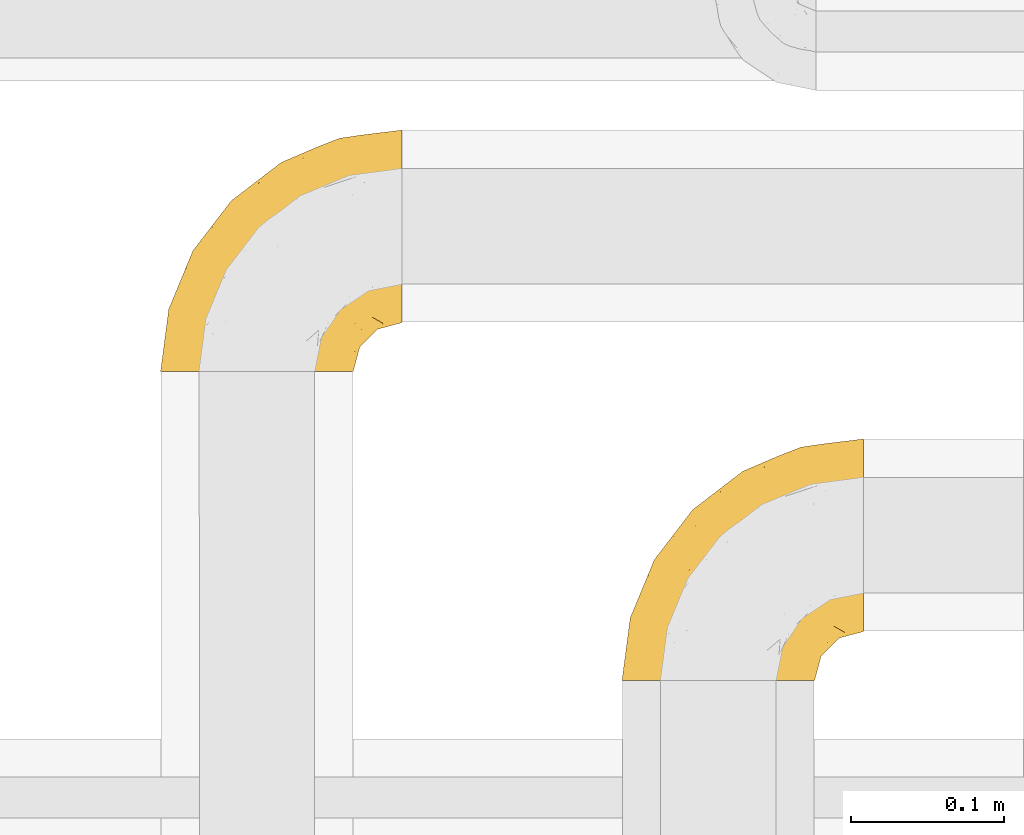
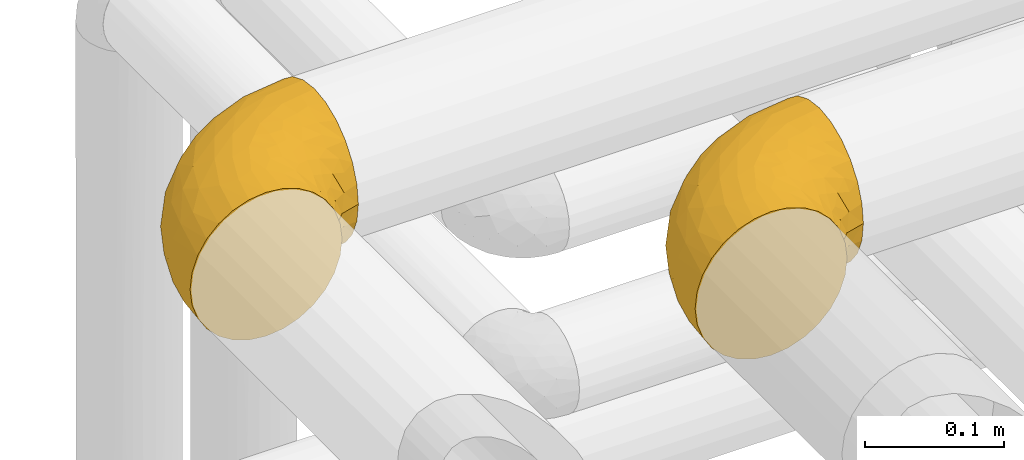
# One storey, part 360 of 827: 2 coverings.
"""IFC2X3 building model written with IfcOpenShell, lengths in millimetres."""

from ifc_helpers import new_model, entity, si_unit, converted_unit, derived_unit, direction, frame, origin, place, context, subcontext, project, spatial, faceted_brep, element, save


model = new_model("IFC2X3")

# Units and contexts
model_context = context("Model", 3, precision=0.01, world=origin(), true_north=direction((6.12303176911189e-17, 1.0)))
body_context = subcontext(model_context, "Body", "Model", "MODEL_VIEW")
ifc_project = project(units=[si_unit("LENGTHUNIT", "METRE", prefix="MILLI"), si_unit("AREAUNIT", "SQUARE_METRE"), si_unit("VOLUMEUNIT", "CUBIC_METRE"), converted_unit("PLANEANGLEUNIT", "DEGREE", entity("IfcRatioMeasure", 0.0174532925199433), si_unit("PLANEANGLEUNIT", "RADIAN"), dimensions=[0, 0, 0, 0, 0, 0, 0]), si_unit("MASSUNIT", "GRAM", prefix="KILO"), derived_unit("MASSDENSITYUNIT", [(si_unit("MASSUNIT", "GRAM", prefix="KILO"), 1), (si_unit("LENGTHUNIT", "METRE"), -3)]), derived_unit("MOMENTOFINERTIAUNIT", [(si_unit("LENGTHUNIT", "METRE"), 4)]), si_unit("TIMEUNIT", "SECOND"), si_unit("FREQUENCYUNIT", "HERTZ"), si_unit("THERMODYNAMICTEMPERATUREUNIT", "DEGREE_CELSIUS"), derived_unit("THERMALTRANSMITTANCEUNIT", [(si_unit("MASSUNIT", "GRAM", prefix="KILO"), 1), (si_unit("THERMODYNAMICTEMPERATUREUNIT", "KELVIN"), -1), (si_unit("TIMEUNIT", "SECOND"), -3)]), derived_unit("VOLUMETRICFLOWRATEUNIT", [(si_unit("LENGTHUNIT", "METRE"), 3), (si_unit("TIMEUNIT", "SECOND"), -1)]), derived_unit("MASSFLOWRATEUNIT", [(si_unit("MASSUNIT", "GRAM", prefix="KILO"), 1), (si_unit("TIMEUNIT", "SECOND"), -1)]), derived_unit("ROTATIONALFREQUENCYUNIT", [(si_unit("TIMEUNIT", "SECOND"), -1)]), si_unit("ELECTRICCURRENTUNIT", "AMPERE"), si_unit("ELECTRICVOLTAGEUNIT", "VOLT"), si_unit("POWERUNIT", "WATT"), si_unit("FORCEUNIT", "NEWTON", prefix="KILO"), si_unit("ILLUMINANCEUNIT", "LUX"), si_unit("LUMINOUSFLUXUNIT", "LUMEN"), si_unit("LUMINOUSINTENSITYUNIT", "CANDELA"), derived_unit("USERDEFINED", [(si_unit("MASSUNIT", "GRAM", prefix="KILO"), -1), (si_unit("LENGTHUNIT", "METRE"), -2), (si_unit("TIMEUNIT", "SECOND"), 3), (si_unit("LUMINOUSFLUXUNIT", "LUMEN"), 1)]), derived_unit("LINEARVELOCITYUNIT", [(si_unit("LENGTHUNIT", "METRE"), 1), (si_unit("TIMEUNIT", "SECOND"), -1)]), si_unit("PRESSUREUNIT", "PASCAL"), derived_unit("USERDEFINED", [(si_unit("LENGTHUNIT", "METRE"), -2), (si_unit("MASSUNIT", "GRAM", prefix="KILO"), 1), (si_unit("TIMEUNIT", "SECOND"), -2)]), derived_unit("LINEARFORCEUNIT", [(si_unit("MASSUNIT", "GRAM", prefix="KILO"), 1), (si_unit("LENGTHUNIT", "METRE"), 1), (si_unit("TIMEUNIT", "SECOND"), -2), (si_unit("LENGTHUNIT", "METRE"), -1)]), derived_unit("PLANARFORCEUNIT", [(si_unit("MASSUNIT", "GRAM", prefix="KILO"), 1), (si_unit("LENGTHUNIT", "METRE"), 1), (si_unit("TIMEUNIT", "SECOND"), -2), (si_unit("LENGTHUNIT", "METRE"), -2)])], contexts=[model_context])

# Site, building, storey
site_placement = place(None, origin())
site = spatial("IfcSite", under=ifc_project, at=site_placement, CompositionType="ELEMENT")
building_placement = place(site_placement, origin())
building = spatial("IfcBuilding", under=site, at=building_placement, CompositionType="ELEMENT")
storey_placement = place(building_placement, frame((0.0, 0.0, 28200.0)))
storey = spatial("IfcBuildingStorey", under=building, at=storey_placement, Name="08", CompositionType="ELEMENT", Elevation=28200.0)

# Coverings
covering_1_placement = place(storey_placement, frame((35853.29, 18712.29, 3485.35)))
element("IfcCovering", 1, at=covering_1_placement, inside=storey, Name=":ADSK_", ObjectType=":ADSK_", PredefinedType="INSULATION", context=body_context, shape_type="Brep", body=[
    faceted_brep([(50.62, 1.61, 126.11), (37.29, 1.6, 121.45), (25.34, 1.6, 113.94), (15.35, 1.6, 103.96), (7.84, 1.6, 92.0), (3.18, 1.6, 78.68), (1.6, 1.6, 64.65), (3.18, 1.6, 50.62), (7.84, 1.6, 37.29), (15.35, 1.6, 25.34), (25.33, 1.6, 15.35), (37.29, 1.6, 7.84), (50.61, 1.61, 3.18), (64.65, 1.61, 1.6), (78.67, 1.61, 3.18), (92.0, 1.62, 7.84), (103.95, 1.62, 15.35), (113.94, 1.62, 25.33), (121.45, 1.62, 37.29), (126.11, 1.62, 50.61), (127.7, 1.62, 64.65), (126.11, 1.62, 78.67), (121.45, 1.62, 92.0), (113.94, 1.62, 103.95), (103.96, 1.62, 113.94), (92.0, 1.62, 121.45), (78.68, 1.61, 126.11), (64.65, 1.61, 127.7), (159.65, 33.58, 64.65), (159.65, 35.73, 48.33), (159.65, 42.03, 33.12), (159.65, 52.05, 20.06), (159.65, 65.11, 10.04), (159.65, 80.31, 3.74), (159.65, 85.92, 3.01), (159.65, 96.63, 1.6), (159.65, 112.95, 3.74), (159.65, 128.16, 10.04), (159.65, 141.22, 20.06), (159.65, 151.24, 33.12), (159.65, 157.53, 48.33), (159.65, 159.68, 64.65), (159.65, 157.53, 80.96), (159.65, 151.24, 96.17), (159.65, 141.22, 109.23), (159.65, 128.16, 119.25), (159.65, 112.95, 125.55), (159.65, 96.63, 127.7), (159.65, 85.92, 126.29), (159.65, 80.31, 125.55), (159.65, 65.11, 119.25), (159.65, 52.05, 109.23), (159.65, 42.03, 96.17), (159.65, 35.73, 80.96), (131.11, 145.27, 101.1), (121.84, 150.98, 86.72), (98.59, 136.52, 98.7), (132.73, 156.34, 75.93), (118.73, 154.3, 64.65), (45.66, 73.94, 113.39), (62.28, 98.97, 111.06), (49.94, 102.75, 96.87), (65.73, 124.92, 84.07), (80.61, 138.5, 64.65), (47.87, 113.38, 64.65), (117.52, 120.37, 119.55), (90.47, 118.45, 112.74), (98.52, 104.03, 122.85), (128.07, 110.09, 125.08), (107.82, 94.64, 126.64), (30.57, 62.69, 105.78), (23.54, 66.8, 93.81), (14.4, 37.71, 96.07), (94.66, 141.15, 87.11), (103.54, 148.33, 75.77), (121.36, 132.8, 111.99), (6.97, 42.51, 64.65), (9.16, 39.36, 83.58), (35.69, 96.18, 80.97), (18.42, 69.17, 78.34), (57.24, 62.73, 122.85), (81.83, 79.43, 125.88), (72.41, 88.84, 120.96), (56.37, 26.95, 126.67), (43.85, 32.14, 122.64), (103.8, 78.48, 127.7), (117.04, 85.23, 127.7), (130.28, 91.98, 127.7), (21.27, 31.66, 107.12), (34.2, 45.39, 115.07), (74.06, 118.92, 102.8), (82.78, 57.46, 127.7), (88.04, 62.72, 127.7), (93.29, 67.97, 127.7), (66.61, 14.01, 127.7), (67.95, 22.49, 127.7), (69.29, 30.97, 127.7), (66.63, 53.44, 126.64), (76.04, 44.22, 127.7), (22.76, 80.64, 64.65), (147.25, 94.67, 127.7), (120.77, 39.98, 113.06), (128.88, 33.19, 101.82), (132.53, 43.24, 108.46), (145.71, 81.81, 126.21), (132.18, 66.34, 122.65), (121.21, 75.26, 126.55), (115.88, 66.59, 125.45), (134.77, 78.22, 126.01), (113.66, 56.89, 123.31), (124.95, 54.27, 119.0), (105.66, 12.97, 113.51), (116.21, 17.45, 104.6), (103.69, 27.08, 118.04), (149.68, 44.4, 101.6), (142.04, 49.7, 109.99), (151.16, 38.92, 92.1), (140.2, 37.12, 96.28), (145.71, 67.0, 121.06), (147.4, 33.03, 79.4), (128.57, 14.55, 79.19), (136.38, 26.35, 80.4), (126.92, 22.4, 93.14), (79.77, 27.98, 126.75), (89.97, 39.49, 125.71), (79.6, 15.43, 126.17), (131.97, 17.6, 64.65), (90.59, 21.34, 123.28), (129.31, 7.64, 64.65), (133.25, 28.96, 91.58), (119.52, 28.68, 107.1), (111.09, 34.85, 116.29), (143.67, 58.31, 116.32), (123.62, 11.76, 90.34), (100.76, 40.39, 122.74), (143.67, 29.3, 64.65), (104.27, 65.16, 126.78), (112.26, 45.43, 119.84), (103.94, 53.07, 124.71), (92.98, 50.42, 126.47), (151.16, 38.92, 37.19), (144.66, 42.93, 27.66), (147.4, 33.03, 49.89), (147.25, 94.67, 1.6), (128.57, 14.55, 50.09), (136.38, 26.35, 48.89), (93.42, 50.53, 2.88), (100.14, 39.44, 6.55), (89.97, 39.49, 3.58), (103.8, 78.48, 1.6), (117.04, 85.23, 1.6), (121.21, 75.26, 2.74), (103.68, 27.08, 11.25), (110.22, 36.38, 11.93), (118.45, 28.93, 21.08), (134.77, 78.22, 3.28), (132.18, 66.34, 6.64), (143.67, 58.31, 12.97), (142.04, 49.7, 19.3), (120.77, 39.99, 16.23), (132.4, 42.46, 21.44), (127.75, 32.6, 26.96), (145.71, 67.0, 8.24), (145.71, 81.81, 3.08), (124.95, 54.27, 10.29), (123.62, 11.76, 38.95), (140.2, 37.12, 33.01), (66.61, 14.01, 1.6), (67.95, 22.49, 1.6), (126.92, 22.4, 36.15), (116.21, 17.45, 24.69), (90.58, 21.34, 6.01), (79.77, 27.98, 2.54), (105.66, 12.97, 15.78), (69.29, 30.97, 1.6), (79.6, 15.43, 3.12), (133.38, 29.33, 37.33), (82.78, 57.46, 1.6), (76.04, 44.22, 1.6), (104.27, 65.16, 2.51), (115.88, 66.59, 3.84), (113.66, 56.89, 5.99), (112.96, 46.44, 9.35), (93.29, 67.97, 1.6), (103.93, 53.07, 4.58), (130.28, 91.98, 1.6), (98.59, 136.52, 30.59), (131.11, 145.27, 28.19), (121.36, 132.8, 17.3), (117.52, 120.37, 9.74), (121.84, 150.98, 42.57), (105.45, 149.05, 53.51), (132.84, 156.37, 53.42), (107.82, 94.64, 2.65), (56.37, 26.95, 2.62), (43.85, 32.15, 6.66), (57.24, 62.73, 6.45), (35.69, 96.18, 48.32), (49.94, 102.75, 32.42), (23.54, 66.8, 35.49), (66.63, 53.44, 2.65), (81.83, 79.43, 3.41), (128.07, 110.09, 4.21), (92.45, 140.47, 43.07), (30.57, 62.69, 23.52), (21.27, 31.66, 22.18), (12.64, 29.32, 33.1), (45.65, 73.94, 15.9), (34.2, 45.39, 14.23), (90.47, 118.45, 16.55), (65.73, 124.92, 45.22), (98.52, 104.03, 6.45), (72.41, 88.84, 8.33), (62.28, 98.97, 18.23), (72.15, 122.88, 32.98), (82.53, 138.42, 53.35), (19.01, 69.19, 48.76), (9.16, 39.36, 45.72)], [[[0, 1, 2, 3, 4, 5, 6, 7, 8, 9, 10, 11, 12, 13, 14, 15, 16, 17, 18, 19, 20, 21, 22, 23, 24, 25, 26, 27]], [[28, 29, 30, 31, 32, 33, 34, 35, 36, 37, 38, 39, 40, 41, 42, 43, 44, 45, 46, 47, 48, 49, 50, 51, 52, 53]], [[54, 55, 56]], [[57, 41, 58]], [[59, 60, 61]], [[62, 63, 64]], [[65, 66, 67]], [[68, 67, 69]], [[70, 71, 72]], [[55, 73, 56]], [[43, 42, 55]], [[55, 74, 73]], [[44, 75, 45]], [[44, 43, 54]], [[76, 5, 77]], [[71, 78, 79]], [[45, 75, 65]], [[46, 68, 47]], [[80, 81, 82]], [[0, 83, 84]], [[69, 85, 86, 87]], [[69, 81, 85]], [[84, 1, 0]], [[2, 88, 3]], [[4, 3, 72]], [[44, 54, 75]], [[5, 4, 77]], [[89, 2, 1]], [[72, 3, 88]], [[5, 76, 6]], [[70, 88, 89]], [[68, 65, 67]], [[88, 2, 89]], [[56, 90, 66]], [[64, 78, 62]], [[81, 91, 92, 93, 85]], [[83, 27, 94, 95, 96]], [[62, 61, 90]], [[97, 96, 98, 91]], [[80, 97, 81]], [[42, 57, 55]], [[62, 78, 61]], [[84, 89, 1]], [[78, 64, 99]], [[57, 74, 55]], [[76, 77, 79]], [[77, 72, 71]], [[82, 81, 67]], [[97, 83, 96]], [[80, 89, 84]], [[79, 78, 99]], [[71, 70, 61]], [[81, 97, 91]], [[83, 80, 84]], [[68, 87, 100, 47]], [[81, 69, 67]], [[68, 69, 87]], [[65, 46, 45]], [[65, 68, 46]], [[66, 65, 75]], [[56, 66, 75]], [[66, 60, 82]], [[71, 61, 78]], [[60, 66, 90]], [[83, 97, 80]], [[27, 83, 0]], [[59, 70, 89]], [[70, 59, 61]], [[89, 80, 59]], [[82, 59, 80]], [[55, 54, 43]], [[75, 54, 56]], [[66, 82, 67]], [[59, 82, 60]], [[41, 57, 42]], [[74, 57, 58]], [[58, 63, 74]], [[62, 74, 63]], [[74, 62, 73]], [[62, 56, 73]], [[4, 72, 77]], [[70, 72, 88]], [[76, 79, 99]], [[71, 79, 77]], [[62, 90, 56]], [[60, 90, 61]], [[101, 102, 103]], [[100, 87, 104]], [[105, 106, 107]], [[108, 104, 87]], [[107, 109, 110]], [[108, 87, 86]], [[111, 112, 113]], [[114, 51, 115]], [[116, 114, 117]], [[51, 50, 118]], [[119, 28, 53]], [[120, 121, 122]], [[98, 123, 124]], [[125, 96, 95]], [[116, 53, 52]], [[126, 121, 120]], [[104, 108, 118]], [[98, 124, 91]], [[25, 24, 127]], [[120, 128, 126]], [[122, 129, 102]], [[95, 94, 27, 26]], [[122, 102, 130]], [[125, 127, 123]], [[24, 111, 127]], [[21, 20, 128]], [[112, 130, 131]], [[48, 47, 100, 49]], [[132, 110, 115]], [[23, 111, 24]], [[129, 119, 117]], [[120, 133, 21]], [[112, 23, 22]], [[134, 113, 131]], [[121, 126, 135]], [[133, 112, 22]], [[128, 120, 21]], [[132, 51, 118]], [[120, 122, 133]], [[119, 121, 135]], [[129, 117, 102]], [[125, 26, 25]], [[26, 125, 95]], [[127, 125, 25]], [[28, 119, 135]], [[119, 53, 116]], [[127, 113, 124]], [[96, 125, 123]], [[112, 131, 113]], [[101, 103, 110]], [[85, 93, 136]], [[124, 123, 127]], [[98, 96, 123]], [[112, 111, 23]], [[127, 111, 113]], [[112, 133, 122]], [[21, 133, 22]], [[107, 110, 105]], [[110, 109, 137]], [[86, 106, 108]], [[138, 109, 136]], [[105, 118, 108]], [[107, 106, 85]], [[104, 50, 49]], [[124, 134, 139]], [[138, 93, 92]], [[92, 91, 139]], [[100, 104, 49]], [[118, 105, 132]], [[104, 118, 50]], [[110, 132, 105]], [[51, 132, 115]], [[108, 106, 105]], [[85, 106, 86]], [[114, 116, 52]], [[119, 116, 117]], [[51, 114, 52]], [[114, 115, 103]], [[117, 114, 103]], [[130, 102, 101]], [[117, 103, 102]], [[110, 103, 115]], [[130, 101, 131]], [[122, 130, 112]], [[101, 137, 131]], [[113, 134, 124]], [[137, 134, 131]], [[124, 139, 91]], [[134, 138, 139]], [[92, 139, 138]], [[110, 137, 101]], [[134, 137, 138]], [[136, 109, 107]], [[137, 109, 138]], [[85, 136, 107]], [[138, 136, 93]], [[122, 121, 129]], [[129, 121, 119]], [[30, 140, 141]], [[30, 29, 140]], [[28, 135, 142]], [[143, 35, 34, 33]], [[19, 144, 128]], [[126, 145, 135]], [[146, 147, 148]], [[149, 150, 151]], [[152, 153, 154]], [[155, 156, 151]], [[157, 31, 158]], [[159, 160, 161]], [[32, 162, 163]], [[158, 31, 30]], [[157, 164, 156]], [[126, 144, 145]], [[126, 128, 144]], [[18, 165, 19]], [[141, 166, 160]], [[14, 13, 167, 168]], [[163, 143, 33]], [[169, 165, 170]], [[18, 17, 170]], [[153, 159, 154]], [[142, 135, 145]], [[148, 171, 172]], [[159, 161, 154]], [[171, 152, 173]], [[173, 17, 16]], [[16, 15, 171]], [[158, 160, 164]], [[174, 175, 168]], [[173, 170, 17]], [[19, 128, 20]], [[174, 172, 175]], [[165, 169, 144]], [[162, 157, 156]], [[175, 172, 171]], [[144, 169, 145]], [[176, 169, 161]], [[166, 140, 142]], [[175, 171, 15]], [[168, 175, 14]], [[14, 175, 15]], [[142, 145, 176]], [[28, 142, 29]], [[148, 177, 146]], [[148, 178, 177]], [[152, 171, 148]], [[179, 180, 181]], [[164, 180, 156]], [[174, 178, 172]], [[148, 172, 178]], [[171, 173, 16]], [[170, 173, 152]], [[19, 165, 144]], [[170, 165, 18]], [[153, 182, 159]], [[146, 183, 184]], [[181, 180, 164]], [[180, 151, 156]], [[163, 155, 185]], [[155, 150, 185]], [[162, 156, 155]], [[143, 163, 185]], [[180, 179, 149]], [[32, 163, 33]], [[163, 162, 155]], [[31, 162, 32]], [[31, 157, 162]], [[164, 157, 158]], [[149, 151, 180]], [[155, 151, 150]], [[142, 140, 29]], [[141, 140, 166]], [[176, 145, 169]], [[30, 141, 158]], [[164, 160, 159]], [[158, 141, 160]], [[166, 161, 160]], [[154, 169, 170]], [[169, 154, 161]], [[152, 154, 170]], [[147, 152, 148]], [[153, 147, 182]], [[181, 182, 184]], [[164, 159, 182]], [[161, 166, 176]], [[142, 176, 166]], [[183, 146, 177]], [[184, 182, 147]], [[184, 147, 146]], [[152, 147, 153]], [[182, 181, 164]], [[179, 184, 183]], [[184, 179, 181]], [[149, 179, 183]], [[186, 187, 188]], [[37, 36, 189]], [[190, 191, 192]], [[193, 185, 150, 149]], [[194, 195, 196]], [[197, 198, 199]], [[200, 201, 177]], [[193, 202, 185]], [[203, 190, 186]], [[202, 189, 36]], [[41, 40, 192]], [[204, 205, 199]], [[9, 8, 206]], [[187, 190, 39]], [[40, 39, 190]], [[38, 37, 188]], [[207, 208, 204]], [[202, 35, 143, 185]], [[39, 38, 187]], [[195, 11, 208]], [[201, 149, 183, 177]], [[188, 189, 209]], [[197, 64, 210]], [[186, 188, 209]], [[13, 12, 194]], [[211, 201, 212]], [[12, 11, 195]], [[193, 201, 211]], [[212, 201, 196]], [[10, 208, 11]], [[213, 214, 209]], [[64, 63, 215]], [[216, 197, 199]], [[8, 217, 206]], [[7, 217, 8]], [[203, 191, 190]], [[7, 6, 76]], [[208, 205, 204]], [[205, 10, 9]], [[199, 205, 206]], [[7, 76, 217]], [[205, 208, 10]], [[216, 76, 99]], [[200, 177, 178, 174]], [[64, 197, 99]], [[63, 58, 191]], [[208, 196, 195]], [[196, 200, 194]], [[198, 197, 210]], [[216, 199, 217]], [[201, 193, 149]], [[202, 193, 211]], [[202, 211, 189]], [[35, 202, 36]], [[211, 212, 209]], [[37, 189, 188]], [[211, 209, 189]], [[213, 198, 214]], [[200, 174, 194]], [[201, 200, 196]], [[214, 198, 210]], [[213, 207, 198]], [[194, 174, 168, 167, 13]], [[195, 194, 12]], [[198, 204, 199]], [[204, 198, 207]], [[212, 207, 213]], [[196, 208, 207]], [[188, 187, 38]], [[190, 187, 186]], [[207, 212, 196]], [[209, 212, 213]], [[214, 203, 186]], [[191, 215, 63]], [[191, 203, 215]], [[192, 191, 58]], [[41, 192, 58]], [[190, 192, 40]], [[203, 210, 215]], [[64, 215, 210]], [[199, 206, 217]], [[9, 206, 205]], [[76, 216, 217]], [[99, 197, 216]], [[203, 214, 210]], [[209, 214, 186]]]),
])
covering_2_placement = place(storey_placement, frame((36155.39, 18510.1, 3485.35)))
element("IfcCovering", 2, at=covering_2_placement, inside=storey, Name=":ADSK_", ObjectType=":ADSK_", PredefinedType="INSULATION", context=body_context, shape_type="Brep", body=[
    faceted_brep([(50.62, 1.6, 126.11), (37.29, 1.6, 121.45), (25.34, 1.6, 113.94), (15.35, 1.6, 103.96), (7.84, 1.6, 92.0), (3.18, 1.6, 78.68), (1.6, 1.6, 64.65), (3.18, 1.6, 50.62), (7.84, 1.6, 37.29), (15.35, 1.6, 25.34), (25.33, 1.6, 15.35), (37.29, 1.6, 7.84), (50.61, 1.6, 3.18), (64.65, 1.6, 1.6), (78.67, 1.6, 3.18), (92.0, 1.6, 7.84), (103.95, 1.6, 15.35), (113.94, 1.6, 25.33), (121.45, 1.6, 37.29), (126.11, 1.6, 50.61), (127.7, 1.6, 64.65), (126.11, 1.6, 78.67), (121.45, 1.6, 92.0), (113.94, 1.6, 103.95), (103.96, 1.6, 113.94), (92.0, 1.6, 121.45), (78.68, 1.6, 126.11), (64.65, 1.6, 127.7), (159.65, 33.55, 64.65), (159.65, 35.69, 48.33), (159.65, 41.99, 33.12), (159.65, 52.01, 20.06), (159.65, 65.07, 10.04), (159.65, 80.28, 3.74), (159.65, 85.89, 3.01), (159.65, 96.6, 1.6), (159.65, 112.91, 3.74), (159.65, 128.12, 10.04), (159.65, 141.18, 20.06), (159.65, 151.2, 33.12), (159.65, 157.5, 48.33), (159.65, 159.65, 64.65), (159.65, 157.5, 80.96), (159.65, 151.2, 96.17), (159.65, 141.18, 109.23), (159.65, 128.12, 119.25), (159.65, 112.91, 125.55), (159.65, 96.6, 127.7), (159.65, 85.89, 126.29), (159.65, 80.28, 125.55), (159.65, 65.07, 119.25), (159.65, 52.01, 109.23), (159.65, 41.99, 96.17), (159.65, 35.69, 80.96), (131.11, 145.23, 101.1), (121.84, 150.95, 86.72), (98.59, 136.48, 98.7), (132.73, 156.3, 75.93), (118.74, 154.26, 64.65), (45.67, 73.92, 113.39), (62.3, 98.94, 111.06), (49.95, 102.72, 96.87), (65.74, 124.89, 84.07), (80.62, 138.47, 64.65), (47.89, 113.35, 64.65), (117.53, 120.33, 119.56), (90.48, 118.42, 112.75), (98.53, 103.99, 122.85), (128.08, 110.05, 125.08), (107.83, 94.6, 126.64), (30.59, 62.68, 105.78), (23.56, 66.8, 93.81), (14.41, 37.71, 96.07), (94.66, 141.12, 87.11), (103.54, 148.29, 75.77), (121.36, 132.76, 111.99), (6.98, 42.5, 64.65), (9.17, 39.36, 83.58), (35.7, 96.16, 80.96), (18.43, 69.16, 78.34), (57.25, 62.71, 122.85), (81.84, 79.4, 125.88), (72.43, 88.81, 120.97), (56.38, 26.93, 126.67), (43.86, 32.13, 122.64), (103.81, 78.45, 127.7), (117.05, 85.2, 127.7), (130.29, 91.95, 127.7), (21.28, 31.66, 107.12), (34.21, 45.38, 115.07), (74.07, 118.88, 102.81), (82.79, 57.43, 127.7), (88.04, 62.69, 127.7), (93.3, 67.94, 127.7), (66.61, 13.99, 127.7), (67.95, 22.47, 127.7), (69.29, 30.95, 127.7), (66.64, 53.41, 126.64), (76.04, 44.19, 127.7), (22.77, 80.62, 64.65), (147.25, 94.63, 127.7), (120.78, 39.95, 113.05), (128.88, 33.15, 101.81), (132.53, 43.2, 108.46), (145.71, 81.77, 126.21), (132.18, 66.3, 122.65), (121.21, 75.23, 126.55), (115.88, 66.55, 125.45), (134.78, 78.18, 126.01), (113.68, 56.85, 123.3), (124.96, 54.23, 118.99), (105.67, 12.94, 113.51), (116.22, 17.42, 104.6), (103.69, 27.05, 118.04), (149.68, 44.37, 101.6), (142.04, 49.66, 109.98), (151.17, 38.88, 92.1), (140.2, 37.08, 96.28), (145.72, 66.96, 121.05), (147.4, 32.99, 79.4), (128.57, 14.52, 79.19), (136.38, 26.32, 80.39), (126.93, 22.37, 93.14), (79.77, 27.96, 126.75), (89.98, 39.47, 125.71), (79.6, 15.41, 126.17), (131.98, 17.57, 64.65), (90.59, 21.32, 123.28), (129.31, 7.61, 64.65), (133.25, 28.92, 91.58), (119.53, 28.65, 107.1), (111.1, 34.82, 116.28), (143.67, 58.27, 116.32), (123.62, 11.73, 90.34), (100.76, 40.36, 122.74), (143.67, 29.26, 64.65), (104.28, 65.12, 126.77), (112.26, 45.4, 119.84), (103.95, 53.05, 124.71), (92.99, 50.39, 126.47), (151.17, 38.88, 37.19), (144.66, 42.9, 27.66), (147.4, 32.99, 49.9), (147.25, 94.63, 1.6), (128.57, 14.52, 50.1), (136.38, 26.32, 48.89), (93.43, 50.51, 2.88), (100.15, 39.41, 6.55), (89.98, 39.47, 3.58), (103.81, 78.45, 1.6), (117.05, 85.2, 1.6), (121.21, 75.23, 2.74), (103.69, 27.05, 11.25), (110.23, 36.34, 11.93), (118.45, 28.89, 21.09), (134.78, 78.18, 3.28), (132.18, 66.3, 6.64), (143.67, 58.27, 12.97), (142.04, 49.66, 19.31), (120.78, 39.95, 16.23), (132.4, 42.42, 21.44), (127.76, 32.56, 26.96), (145.72, 66.96, 8.24), (145.71, 81.77, 3.08), (124.96, 54.23, 10.3), (123.62, 11.73, 38.95), (140.2, 37.08, 33.01), (66.61, 13.99, 1.6), (67.95, 22.47, 1.6), (126.93, 22.37, 36.15), (116.21, 17.42, 24.69), (90.59, 21.32, 6.01), (79.77, 27.96, 2.54), (105.66, 12.94, 15.78), (69.29, 30.95, 1.6), (79.6, 15.41, 3.12), (133.38, 29.3, 37.33), (82.79, 57.43, 1.6), (76.04, 44.19, 1.6), (104.28, 65.12, 2.52), (115.88, 66.55, 3.84), (113.68, 56.85, 5.99), (112.97, 46.41, 9.35), (93.3, 67.94, 1.6), (103.94, 53.04, 4.58), (130.29, 91.95, 1.6), (98.59, 136.48, 30.59), (131.11, 145.23, 28.19), (121.36, 132.76, 17.3), (117.53, 120.33, 9.73), (121.84, 150.95, 42.57), (105.45, 149.01, 53.51), (132.83, 156.33, 53.42), (107.83, 94.6, 2.65), (56.38, 26.93, 2.62), (43.85, 32.14, 6.66), (57.25, 62.71, 6.44), (35.7, 96.16, 48.33), (49.95, 102.72, 32.42), (23.55, 66.79, 35.49), (66.64, 53.41, 2.65), (81.84, 79.4, 3.41), (128.08, 110.05, 4.21), (92.46, 140.44, 43.07), (30.58, 62.68, 23.52), (21.27, 31.66, 22.18), (12.64, 29.31, 33.1), (45.66, 73.92, 15.9), (34.21, 45.39, 14.23), (90.48, 118.42, 16.54), (65.74, 124.89, 45.22), (98.53, 103.99, 6.44), (72.43, 88.81, 8.33), (62.3, 98.94, 18.23), (72.15, 122.85, 32.99), (82.52, 138.38, 53.35), (19.03, 69.18, 48.76), (9.17, 39.36, 45.72)], [[[0, 1, 2, 3, 4, 5, 6, 7, 8, 9, 10, 11, 12, 13, 14, 15, 16, 17, 18, 19, 20, 21, 22, 23, 24, 25, 26, 27]], [[28, 29, 30, 31, 32, 33, 34, 35, 36, 37, 38, 39, 40, 41, 42, 43, 44, 45, 46, 47, 48, 49, 50, 51, 52, 53]], [[54, 55, 56]], [[57, 41, 58]], [[59, 60, 61]], [[62, 63, 64]], [[65, 66, 67]], [[68, 67, 69]], [[70, 71, 72]], [[55, 73, 56]], [[43, 42, 55]], [[55, 74, 73]], [[44, 75, 45]], [[44, 43, 54]], [[76, 5, 77]], [[71, 78, 79]], [[45, 75, 65]], [[46, 68, 47]], [[80, 81, 82]], [[0, 83, 84]], [[69, 85, 86, 87]], [[69, 81, 85]], [[84, 1, 0]], [[2, 88, 3]], [[4, 3, 72]], [[44, 54, 75]], [[5, 4, 77]], [[89, 2, 1]], [[72, 3, 88]], [[5, 76, 6]], [[70, 88, 89]], [[68, 65, 67]], [[88, 2, 89]], [[56, 90, 66]], [[64, 78, 62]], [[81, 91, 92, 93, 85]], [[83, 27, 94, 95, 96]], [[62, 61, 90]], [[97, 96, 98, 91]], [[80, 97, 81]], [[42, 57, 55]], [[62, 78, 61]], [[84, 89, 1]], [[78, 64, 99]], [[57, 74, 55]], [[76, 77, 79]], [[77, 72, 71]], [[82, 81, 67]], [[97, 83, 96]], [[80, 89, 84]], [[79, 78, 99]], [[71, 70, 61]], [[81, 97, 91]], [[83, 80, 84]], [[68, 87, 100, 47]], [[81, 69, 67]], [[68, 69, 87]], [[65, 46, 45]], [[65, 68, 46]], [[66, 65, 75]], [[56, 66, 75]], [[66, 60, 82]], [[71, 61, 78]], [[60, 66, 90]], [[83, 97, 80]], [[27, 83, 0]], [[59, 70, 89]], [[70, 59, 61]], [[89, 80, 59]], [[82, 59, 80]], [[55, 54, 43]], [[75, 54, 56]], [[66, 82, 67]], [[59, 82, 60]], [[41, 57, 42]], [[74, 57, 58]], [[58, 63, 74]], [[62, 74, 63]], [[74, 62, 73]], [[62, 56, 73]], [[4, 72, 77]], [[70, 72, 88]], [[76, 79, 99]], [[71, 79, 77]], [[62, 90, 56]], [[60, 90, 61]], [[101, 102, 103]], [[100, 87, 104]], [[105, 106, 107]], [[108, 104, 87]], [[107, 109, 110]], [[108, 87, 86]], [[111, 112, 113]], [[114, 51, 115]], [[116, 114, 117]], [[51, 50, 118]], [[119, 28, 53]], [[120, 121, 122]], [[98, 123, 124]], [[125, 96, 95]], [[116, 53, 52]], [[126, 121, 120]], [[104, 108, 118]], [[98, 124, 91]], [[25, 24, 127]], [[120, 128, 126]], [[122, 129, 102]], [[95, 94, 27, 26]], [[122, 102, 130]], [[125, 127, 123]], [[24, 111, 127]], [[21, 20, 128]], [[112, 130, 131]], [[48, 47, 100, 49]], [[132, 110, 115]], [[23, 111, 24]], [[129, 119, 117]], [[120, 133, 21]], [[112, 23, 22]], [[134, 113, 131]], [[121, 126, 135]], [[133, 112, 22]], [[128, 120, 21]], [[132, 51, 118]], [[120, 122, 133]], [[119, 121, 135]], [[129, 117, 102]], [[125, 26, 25]], [[26, 125, 95]], [[127, 125, 25]], [[28, 119, 135]], [[119, 53, 116]], [[127, 113, 124]], [[96, 125, 123]], [[112, 131, 113]], [[101, 103, 110]], [[85, 93, 136]], [[124, 123, 127]], [[98, 96, 123]], [[112, 111, 23]], [[127, 111, 113]], [[112, 133, 122]], [[21, 133, 22]], [[107, 110, 105]], [[110, 109, 137]], [[86, 106, 108]], [[138, 109, 136]], [[105, 118, 108]], [[107, 106, 85]], [[104, 50, 49]], [[124, 134, 139]], [[138, 93, 92]], [[92, 91, 139]], [[100, 104, 49]], [[118, 105, 132]], [[104, 118, 50]], [[110, 132, 105]], [[51, 132, 115]], [[108, 106, 105]], [[85, 106, 86]], [[114, 116, 52]], [[119, 116, 117]], [[51, 114, 52]], [[114, 115, 103]], [[117, 114, 103]], [[130, 102, 101]], [[117, 103, 102]], [[110, 103, 115]], [[130, 101, 131]], [[122, 130, 112]], [[101, 137, 131]], [[113, 134, 124]], [[137, 134, 131]], [[124, 139, 91]], [[134, 138, 139]], [[92, 139, 138]], [[110, 137, 101]], [[134, 137, 138]], [[136, 109, 107]], [[137, 109, 138]], [[85, 136, 107]], [[138, 136, 93]], [[122, 121, 129]], [[129, 121, 119]], [[30, 140, 141]], [[30, 29, 140]], [[28, 135, 142]], [[143, 35, 34, 33]], [[19, 144, 128]], [[126, 145, 135]], [[146, 147, 148]], [[149, 150, 151]], [[152, 153, 154]], [[155, 156, 151]], [[157, 31, 158]], [[159, 160, 161]], [[32, 162, 163]], [[158, 31, 30]], [[157, 164, 156]], [[126, 144, 145]], [[126, 128, 144]], [[18, 165, 19]], [[141, 166, 160]], [[14, 13, 167, 168]], [[163, 143, 33]], [[169, 165, 170]], [[18, 17, 170]], [[153, 159, 154]], [[142, 135, 145]], [[148, 171, 172]], [[159, 161, 154]], [[171, 152, 173]], [[173, 17, 16]], [[16, 15, 171]], [[158, 160, 164]], [[174, 175, 168]], [[173, 170, 17]], [[19, 128, 20]], [[174, 172, 175]], [[165, 169, 144]], [[162, 157, 156]], [[175, 172, 171]], [[144, 169, 145]], [[176, 169, 161]], [[166, 140, 142]], [[175, 171, 15]], [[168, 175, 14]], [[14, 175, 15]], [[142, 145, 176]], [[28, 142, 29]], [[148, 177, 146]], [[148, 178, 177]], [[152, 171, 148]], [[179, 180, 181]], [[164, 180, 156]], [[174, 178, 172]], [[148, 172, 178]], [[171, 173, 16]], [[170, 173, 152]], [[19, 165, 144]], [[170, 165, 18]], [[153, 182, 159]], [[146, 183, 184]], [[181, 180, 164]], [[180, 151, 156]], [[163, 155, 185]], [[155, 150, 185]], [[162, 156, 155]], [[143, 163, 185]], [[180, 179, 149]], [[32, 163, 33]], [[163, 162, 155]], [[31, 162, 32]], [[31, 157, 162]], [[164, 157, 158]], [[149, 151, 180]], [[155, 151, 150]], [[142, 140, 29]], [[141, 140, 166]], [[176, 145, 169]], [[30, 141, 158]], [[164, 160, 159]], [[158, 141, 160]], [[166, 161, 160]], [[154, 169, 170]], [[169, 154, 161]], [[152, 154, 170]], [[147, 152, 148]], [[153, 147, 182]], [[181, 182, 184]], [[164, 159, 182]], [[161, 166, 176]], [[142, 176, 166]], [[183, 146, 177]], [[184, 182, 147]], [[184, 147, 146]], [[152, 147, 153]], [[182, 181, 164]], [[179, 184, 183]], [[184, 179, 181]], [[149, 179, 183]], [[186, 187, 188]], [[37, 36, 189]], [[190, 191, 192]], [[193, 185, 150, 149]], [[194, 195, 196]], [[197, 198, 199]], [[200, 201, 177]], [[193, 202, 185]], [[203, 190, 186]], [[202, 189, 36]], [[41, 40, 192]], [[204, 205, 199]], [[9, 8, 206]], [[187, 190, 39]], [[40, 39, 190]], [[38, 37, 188]], [[207, 208, 204]], [[202, 35, 143, 185]], [[39, 38, 187]], [[195, 11, 208]], [[201, 149, 183, 177]], [[188, 189, 209]], [[197, 64, 210]], [[186, 188, 209]], [[13, 12, 194]], [[211, 201, 212]], [[12, 11, 195]], [[193, 201, 211]], [[212, 201, 196]], [[10, 208, 11]], [[213, 214, 209]], [[64, 63, 215]], [[216, 197, 199]], [[8, 217, 206]], [[7, 217, 8]], [[203, 191, 190]], [[7, 6, 76]], [[208, 205, 204]], [[205, 10, 9]], [[199, 205, 206]], [[7, 76, 217]], [[205, 208, 10]], [[216, 76, 99]], [[200, 177, 178, 174]], [[64, 197, 99]], [[63, 58, 191]], [[208, 196, 195]], [[196, 200, 194]], [[198, 197, 210]], [[216, 199, 217]], [[201, 193, 149]], [[202, 193, 211]], [[202, 211, 189]], [[35, 202, 36]], [[211, 212, 209]], [[37, 189, 188]], [[211, 209, 189]], [[213, 198, 214]], [[200, 174, 194]], [[201, 200, 196]], [[214, 198, 210]], [[213, 207, 198]], [[194, 174, 168, 167, 13]], [[195, 194, 12]], [[198, 204, 199]], [[204, 198, 207]], [[212, 207, 213]], [[196, 208, 207]], [[188, 187, 38]], [[190, 187, 186]], [[207, 212, 196]], [[209, 212, 213]], [[214, 203, 186]], [[191, 215, 63]], [[191, 203, 215]], [[192, 191, 58]], [[41, 192, 58]], [[190, 192, 40]], [[203, 210, 215]], [[64, 215, 210]], [[199, 206, 217]], [[9, 206, 205]], [[76, 216, 217]], [[99, 197, 216]], [[203, 214, 210]], [[209, 214, 186]]]),
])

save(model, "model.ifc")
